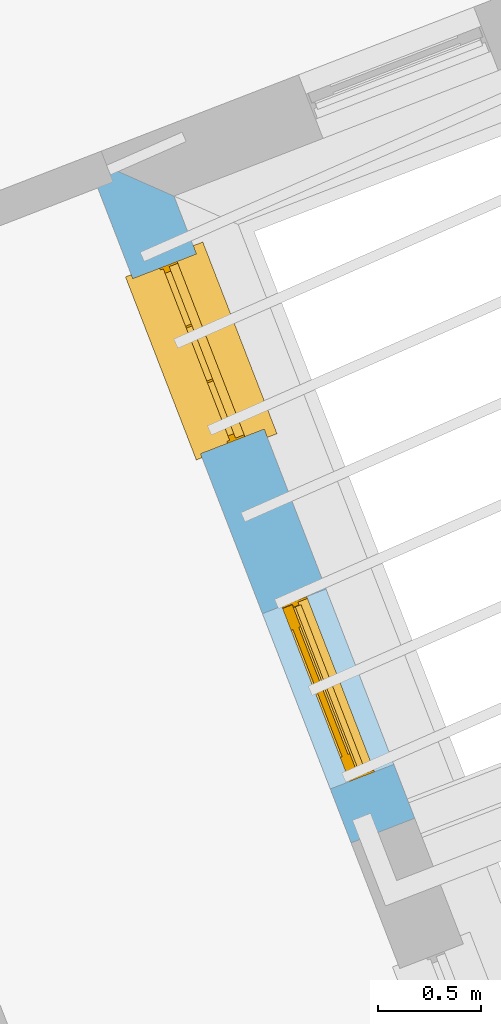
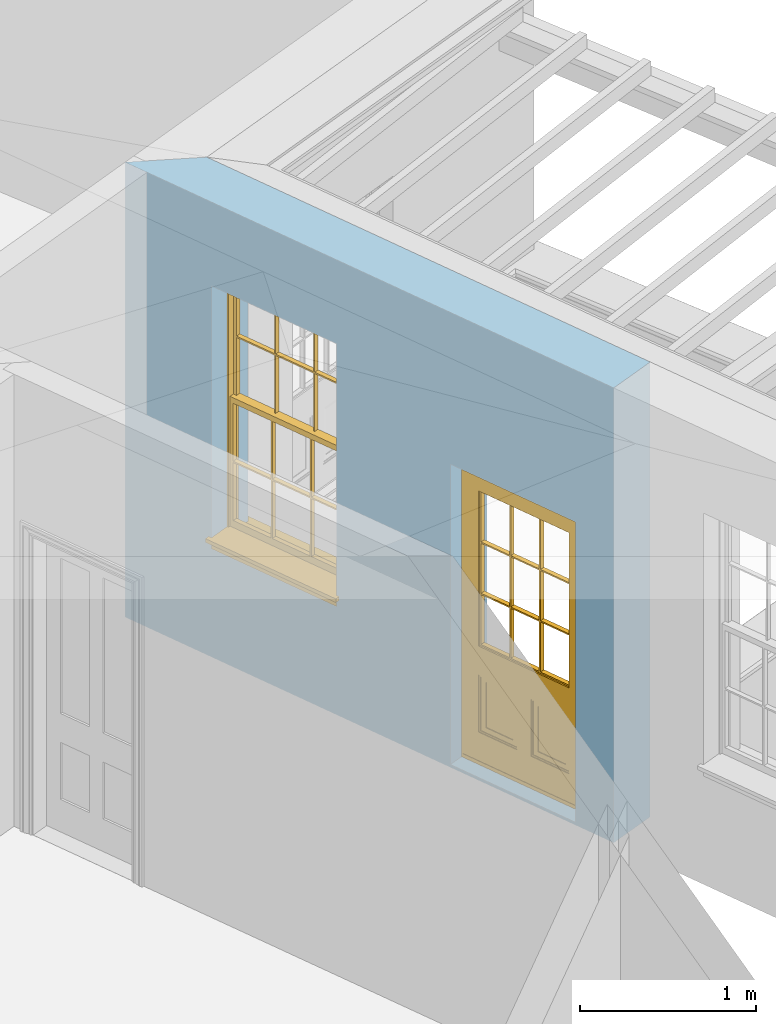
# One storey, part 6 of 11: 1 door, 1 window, 2 openings, plus 1 element that does not belong to this part.
"""IFC2X3 building model written with IfcOpenShell, lengths in metres."""

from ifc_helpers import new_model, si_unit, frame, origin, place, context, subcontext, project, spatial, polyline, outline, extrude, faceted_brep, material, layer, layer_set, layer_usage, element, fill, save


model = new_model("IFC2X3")

# Units and contexts
model_context = context("Model", 3, world=origin())
body_context = subcontext(model_context, "Body", "Model", "MODEL_VIEW")
ifc_project = project(units=[si_unit("PLANEANGLEUNIT", "RADIAN"), si_unit("MASSUNIT", "GRAM", prefix="KILO"), si_unit("FORCEUNIT", "NEWTON", prefix="KILO"), si_unit("LENGTHUNIT", "METRE")], contexts=[model_context])

# Site, building, storey
site_placement = place(None, origin())
site = spatial("IfcSite", under=ifc_project, at=site_placement, CompositionType="ELEMENT")
building_placement = place(None, origin())
building = spatial("IfcBuilding", under=site, at=building_placement, Name="Building plot-5", CompositionType="ELEMENT")
storey_placement = place(None, frame((0.0, 0.0, 7.6)))
storey = spatial("IfcBuildingStorey", under=building, at=storey_placement, Name="Floor 1", CompositionType="ELEMENT", Elevation=7.6)

# Wall, openings, door, window
ifc_material = material(Name="Masonry")
ifc_layer = layer(ifc_material, 0.33, ventilated=False)
ifc_layer_set = layer_set([ifc_layer], Name="My Wall")
ifc_layer_usage = layer_usage(ifc_layer_set, "AXIS2", "NEGATIVE", 0.08)
wall_placement = place(storey_placement, origin())
wall = element("IfcWallStandardCase", 1, at=wall_placement, inside=storey, material=ifc_layer_usage, Name="exterior", context=body_context, shape_type="SweptSolid", body=[
    extrude(outline(polyline([(63.1182699697019, 56.0491056208722), (63.4260314383826, 56.1681975114254), (62.2606962551514, 59.1796978397062), (61.8338428959176, 59.3683674178337), (63.1182699697019, 56.0491056208722)])), origin(), (0.0, 0.0, 1.0), 3.15),
])
opening_1_placement = place(storey_placement, frame((0.0, 0.0, 0.0199999999999996)))
opening_1 = element("IfcOpeningElement", 2, at=opening_1_placement, cuts=wall, Name="Opening", ObjectType="Opening", context=body_context, shape_type="SweptSolid", body=[
    extrude(outline(polyline([(63.3251446767321, 56.4289126431758), (62.9967397664188, 57.2775882083255), (62.6889782977382, 57.1584963177724), (63.0173832080514, 56.3098207526227), (63.3251446767321, 56.4289126431758)])), origin(), (0.0, 0.0, 1.0), 2.08),
])
opening_2_placement = place(storey_placement, frame((0.0, 0.0, 0.75)))
opening_2 = element("IfcOpeningElement", 3, at=opening_2_placement, cuts=wall, Name="Opening", ObjectType="Opening", context=body_context, shape_type="SweptSolid", body=[
    extrude(outline(polyline([(62.697366520513, 58.0512391212105), (62.3689616101998, 58.8999146863601), (62.0612001415191, 58.780822795807), (62.3896050518324, 57.9321472306573), (62.697366520513, 58.0512391212105)])), origin(), (0.0, 0.0, 1.0), 1.82),
])
door_placement = place(storey_placement, frame((63.0919920489437, 56.3386915139689, 0.0199999999999996), z_axis=(0.0, 0.0, 1.0), x_axis=(-0.328404910313289, 0.848675565149676, 0.0)))
door = element("IfcDoor", 4, at=door_placement, inside=storey, Name="circulation outside door", OverallHeight=2.08, OverallWidth=0.91, context=body_context, shape_type="Brep", held_by="IfcProductRepresentation", body=[
    faceted_brep([(0.545, -0.055, 0.265), (0.745, -0.055, 0.265), (0.745, -0.05, 0.265), (0.545, -0.05, 0.265), (0.745, -0.05, 0.58), (0.545, -0.05, 0.58), (0.545, -0.055, 0.58), (0.515, -0.06, 0.235), (0.775, -0.06, 0.235), (0.745, -0.055, 0.58), (0.515, -0.06, 0.61), (0.515, -0.065, 0.235), (0.775, -0.065, 0.235), (0.775, -0.06, 0.61), (0.515, -0.065, 0.61), (0.785, -0.065, 0.225), (0.505, -0.065, 0.225), (0.775, -0.065, 0.61), (0.505, -0.065, 0.62), (0.785, -0.065, 0.62), (0.505, -0.07, 0.225), (0.785, -0.07, 0.225), (0.505, -0.07, 0.62), (0.785, -0.07, 0.62), (0.883, -0.07, 0.075), (0.898, -0.07, 0.075), (0.405, -0.07, 0.62), (0.405, -0.07, 0.225), (0.027, -0.07, 0.075), (0.785, -0.07, 0.82), (0.125, -0.07, 0.82), (0.405, -0.065, 0.62), (0.405, -0.065, 0.225), (0.898, -0.07, 2.068), (0.027, -0.08, 0.075), (0.883, -0.08, 0.075), (0.125, -0.07, 0.225), (0.012, -0.07, 0.075), (0.785, -0.06, 0.82), (0.125, -0.06, 0.82), (0.125, -0.07, 0.62), (0.125, -0.065, 0.62), (0.395, -0.065, 0.61), (0.395, -0.065, 0.235), (0.125, -0.065, 0.225), (0.785, -0.07, 1.895), (0.027, -0.11, 0.045), (0.883, -0.11, 0.045), (0.558333, -0.06, 0.83), (0.351667, -0.06, 0.83), (0.125, -0.07, 1.895), (0.125, -0.06, 1.895), (0.785, -0.06, 1.895), (0.012, -0.07, 2.068), (0.135, -0.065, 0.61), (0.395, -0.06, 0.61), (0.395, -0.06, 0.235), (0.135, -0.065, 0.235), (0.027, -0.11, 0.027), (0.883, -0.11, 0.027), (0.568333, -0.06, 0.83), (0.558333, -0.03, 0.83), (0.351667, -0.03, 0.83), (0.341667, -0.06, 0.83), (0.135, -0.06, 1.185), (0.135, -0.06, 1.53), (0.775, -0.06, 1.53), (0.775, -0.06, 1.185), (0.135, -0.06, 0.61), (0.365, -0.055, 0.58), (0.365, -0.055, 0.265), (0.135, -0.06, 0.235), (0.568333, -0.06, 1.175), (0.558333, -0.06, 1.175), (0.775, -0.06, 0.83), (0.558333, -0.03, 1.175), (0.785, -0.03, 0.82), (0.125, -0.03, 0.82), (0.351667, -0.03, 1.175), (0.351667, -0.06, 1.175), (0.341667, -0.06, 1.175), (0.135, -0.06, 0.83), (0.135, -0.06, 1.175), (0.135, -0.03, 1.185), (0.135, -0.03, 1.53), (0.135, -0.06, 1.54), (0.351667, -0.06, 1.885), (0.558333, -0.06, 1.885), (0.775, -0.03, 1.53), (0.775, -0.03, 1.185), (0.775, -0.06, 1.175), (0.775, -0.06, 1.54), (0.165, -0.055, 0.58), (0.365, -0.05, 0.58), (0.365, -0.05, 0.265), (0.165, -0.055, 0.265), (0.568333, -0.03, 0.83), (0.568333, -0.03, 1.175), (0.568333, -0.06, 1.185), (0.558333, -0.06, 1.185), (0.775, -0.03, 0.83), (0.785, -0.02, 0.82), (0.125, -0.02, 0.82), (0.341667, -0.03, 0.83), (0.341667, -0.03, 1.175), (0.351667, -0.06, 1.185), (0.341667, -0.06, 1.185), (0.135, -0.03, 0.83), (0.341667, -0.03, 1.185), (0.125, -0.03, 1.895), (0.341667, -0.03, 1.53), (0.341667, -0.06, 1.53), (0.135, -0.06, 1.885), (0.341667, -0.06, 1.54), (0.341667, -0.06, 1.885), (0.558333, -0.03, 1.885), (0.351667, -0.03, 1.885), (0.568333, -0.06, 1.885), (0.785, -0.03, 1.895), (0.568333, -0.03, 1.185), (0.568333, -0.06, 1.53), (0.568333, -0.03, 1.53), (0.568333, -0.06, 1.54), (0.775, -0.06, 1.885), (0.165, -0.05, 0.58), (0.165, -0.05, 0.265), (0.775, -0.03, 1.175), (0.558333, -0.06, 1.53), (0.351667, -0.03, 1.185), (0.558333, -0.03, 1.185), (0.505, -0.02, 0.62), (0.405, -0.02, 0.62), (0.125, -0.02, 1.895), (0.785, -0.02, 1.895), (0.351667, -0.06, 1.53), (0.135, -0.03, 1.175), (0.135, -0.03, 1.54), (0.341667, -0.03, 1.54), (0.135, -0.03, 1.885), (0.351667, -0.06, 1.54), (0.558333, -0.03, 1.54), (0.558333, -0.06, 1.54), (0.351667, -0.03, 1.54), (0.775, -0.03, 1.54), (0.568333, -0.03, 1.54), (0.775, -0.03, 1.885), (0.558333, -0.03, 1.53), (0.405, -0.02, 0.225), (0.505, -0.02, 0.225), (0.125, -0.02, 0.62), (0.785, -0.02, 0.62), (0.012, -0.02, 2.068), (0.898, -0.02, 2.068), (0.351667, -0.03, 1.53), (0.341667, -0.03, 1.885), (0.568333, -0.03, 1.885), (0.405, -0.025, 0.225), (0.405, -0.025, 0.62), (0.505, -0.025, 0.62), (0.505, -0.025, 0.225), (0.898, -0.02, 0.027), (0.012, -0.02, 0.027), (0.125, -0.025, 0.62), (0.785, -0.025, 0.62), (0.395, -0.025, 0.235), (0.395, -0.025, 0.61), (0.125, -0.02, 0.225), (0.125, -0.025, 0.225), (0.515, -0.025, 0.61), (0.515, -0.025, 0.235), (0.785, -0.02, 0.225), (0.785, -0.025, 0.225), (0.135, -0.025, 0.61), (0.775, -0.025, 0.61), (0.135, -0.025, 0.235), (0.395, -0.03, 0.235), (0.395, -0.03, 0.61), (0.515, -0.03, 0.61), (0.515, -0.03, 0.235), (0.775, -0.025, 0.235), (0.135, -0.03, 0.61), (0.775, -0.03, 0.61), (0.135, -0.03, 0.235), (0.365, -0.035, 0.265), (0.365, -0.035, 0.58), (0.545, -0.035, 0.58), (0.545, -0.035, 0.265), (0.775, -0.03, 0.235), (0.165, -0.035, 0.58), (0.745, -0.035, 0.58), (0.165, -0.035, 0.265), (0.365, -0.04, 0.58), (0.365, -0.04, 0.265), (0.545, -0.04, 0.58), (0.545, -0.04, 0.265), (0.745, -0.035, 0.265), (0.165, -0.04, 0.58), (0.745, -0.04, 0.58), (0.165, -0.04, 0.265), (0.745, -0.04, 0.265), (0.885, -0.072, 0.025), (0.025, -0.072, 0.025), (0.025, -0.1, 0.025), (0.885, -0.1, 0.025), (0.9, -0.02, 0.025), (0.01, -0.02, 0.025), (0.9, -0.072, 0.025), (0.91, -0.02, 0.0), (0.0, -0.02, 0.0), (0.01, -0.072, 0.025), (0.9, -0.072, 2.07), (0.9, -0.02, 2.07), (0.885, -0.072, 2.055), (0.91, -0.02, 2.08), (0.01, -0.02, 2.07), (0.0, -0.02, 2.08), (0.01, -0.072, 2.07), (0.025, -0.072, 2.055), (0.0, -0.15, 2.08), (0.91, -0.15, 2.08), (0.01, -0.15, 2.07), (0.9, -0.15, 2.07), (0.01, -0.1, 2.07), (0.9, -0.1, 2.07), (0.0, -0.15, 0.0), (0.91, -0.15, 0.0), (0.01, -0.15, 0.025), (0.9, -0.15, 0.025), (0.01, -0.1, 0.025), (0.025, -0.1, 2.055), (0.9, -0.1, 0.025), (0.885, -0.1, 2.055), (0.898, -0.07, 0.027), (0.012, -0.07, 0.027), (0.883, -0.07, 0.027), (0.027, -0.07, 0.027)], [[[0, 1, 2, 3]], [[2, 4, 5, 3]], [[0, 3, 5, 6]], [[1, 0, 7, 8]], [[9, 4, 2, 1]], [[9, 6, 5, 4]], [[0, 6, 10, 7]], [[8, 7, 11, 12]], [[8, 13, 9, 1]], [[13, 10, 6, 9]], [[7, 10, 14, 11]], [[15, 12, 11, 16]], [[12, 17, 13, 8]], [[17, 14, 10, 13]], [[18, 16, 11, 14]], [[15, 19, 17, 12]], [[15, 16, 20, 21]], [[14, 17, 19, 18]], [[16, 18, 22, 20]], [[21, 23, 19, 15]], [[24, 25, 21, 20]], [[23, 22, 18, 19]], [[20, 22, 26, 27]], [[23, 21, 25]], [[28, 24, 20, 27]], [[22, 23, 29]], [[29, 30, 26, 22]], [[27, 26, 31, 32]], [[23, 25, 33, 29]], [[34, 35, 24, 28]], [[28, 27, 36, 37]], [[38, 39, 30, 29]], [[26, 30, 40]], [[26, 40, 41, 31]], [[42, 43, 32, 31]], [[32, 44, 36, 27]], [[33, 45, 29]], [[46, 47, 35, 34]], [[36, 40, 37]], [[39, 38, 48, 49]], [[50, 30, 39, 51]], [[29, 45, 52, 38]], [[53, 37, 40, 30]], [[44, 41, 40, 36]], [[31, 41, 54, 42]], [[43, 42, 55, 56]], [[57, 44, 32, 43]], [[50, 45, 33, 53]], [[47, 46, 58, 59]], [[60, 48, 38]], [[49, 48, 61, 62]], [[49, 63, 39]], [[50, 53, 30]], [[51, 39, 64, 65]], [[45, 50, 51, 52]], [[66, 67, 38, 52]], [[57, 54, 41, 44]], [[42, 54, 68, 55]], [[56, 55, 69, 70]], [[56, 71, 57, 43]], [[60, 72, 73, 48]], [[60, 38, 74]], [[48, 73, 75, 61]], [[76, 77, 62, 61]], [[62, 78, 79, 49]], [[49, 79, 80, 63]], [[63, 81, 39]], [[82, 64, 39]], [[65, 64, 83, 84]], [[85, 51, 65]], [[52, 51, 86, 87]], [[88, 89, 67, 66]], [[90, 38, 67]], [[91, 66, 52]], [[71, 68, 54, 57]], [[55, 68, 92, 69]], [[69, 93, 94, 70]], [[70, 95, 71, 56]], [[96, 97, 72, 60]], [[73, 72, 98, 99]], [[74, 38, 90]], [[100, 96, 60, 74]], [[75, 73, 79, 78]], [[61, 75, 97, 96]], [[101, 102, 77, 76]], [[77, 103, 62]], [[96, 76, 61]], [[103, 104, 78, 62]], [[80, 79, 105, 106]], [[63, 80, 104, 103]], [[81, 63, 103, 107]], [[81, 82, 39]], [[106, 64, 82, 80]], [[106, 108, 83, 64]], [[84, 83, 77, 109]], [[110, 111, 65, 84]], [[112, 51, 85]], [[113, 85, 65, 111]], [[114, 86, 51]], [[115, 87, 86, 116]], [[117, 52, 87]], [[118, 76, 89, 88]], [[119, 98, 67, 89]], [[120, 121, 88, 66]], [[67, 98, 72, 90]], [[91, 122, 120, 66]], [[91, 52, 123]], [[95, 92, 68, 71]], [[69, 92, 124, 93]], [[94, 93, 124, 125]], [[94, 125, 95, 70]], [[72, 97, 126, 90]], [[127, 99, 98, 120]], [[99, 105, 79, 73]], [[74, 90, 126, 100]], [[96, 100, 76]], [[128, 129, 75, 78]], [[97, 75, 129, 119]], [[130, 131, 102, 101]], [[109, 77, 102, 132]], [[133, 101, 76, 118]], [[77, 107, 103]], [[78, 104, 108, 128]], [[111, 106, 105, 134]], [[104, 80, 82, 135]], [[107, 135, 82, 81]], [[110, 108, 106, 111]], [[104, 135, 83, 108]], [[83, 135, 77]], [[136, 84, 109]], [[110, 84, 136, 137]], [[114, 51, 112]], [[85, 136, 138, 112]], [[113, 137, 136, 85]], [[111, 134, 139, 113]], [[86, 114, 113, 139]], [[140, 141, 87, 115]], [[139, 142, 116, 86]], [[109, 118, 115, 116]], [[117, 123, 52]], [[117, 87, 141, 122]], [[126, 89, 76]], [[143, 118, 88]], [[120, 98, 119, 121]], [[119, 89, 126, 97]], [[144, 143, 88, 121]], [[144, 122, 91, 143]], [[127, 120, 122, 141]], [[143, 91, 123, 145]], [[124, 92, 95, 125]], [[146, 129, 99, 127]], [[99, 129, 128, 105]], [[100, 126, 76]], [[121, 119, 129, 146]], [[147, 131, 130, 148]], [[131, 149, 102]], [[130, 101, 150]], [[102, 151, 132]], [[118, 109, 132, 133]], [[101, 133, 152]], [[107, 77, 135]], [[153, 128, 108, 110]], [[134, 105, 128, 153]], [[109, 138, 136]], [[153, 110, 137, 142]], [[154, 114, 112, 138]], [[137, 113, 114, 154]], [[141, 139, 134, 127]], [[141, 140, 142, 139]], [[144, 140, 115, 155]], [[142, 137, 154, 116]], [[155, 115, 118]], [[116, 154, 109]], [[117, 155, 145, 123]], [[122, 144, 155, 117]], [[143, 145, 118]], [[121, 146, 140, 144]], [[146, 127, 134, 153]], [[156, 157, 131, 147]], [[148, 130, 158, 159]], [[148, 160, 161, 147]], [[157, 162, 149, 131]], [[161, 151, 102, 149]], [[101, 152, 160, 150]], [[163, 158, 130, 150]], [[151, 152, 133, 132]], [[154, 138, 109]], [[142, 140, 146, 153]], [[145, 155, 118]], [[157, 156, 164, 165]], [[147, 166, 167, 156]], [[168, 169, 159, 158]], [[170, 148, 159, 171]], [[148, 170, 160]], [[166, 147, 161]], [[172, 162, 157, 165]], [[166, 149, 162, 167]], [[166, 161, 149]], [[150, 160, 170]], [[163, 173, 168, 158]], [[171, 163, 150, 170]], [[174, 164, 156, 167]], [[175, 176, 165, 164]], [[169, 168, 177, 178]], [[171, 159, 169, 179]], [[167, 162, 172, 174]], [[176, 180, 172, 165]], [[179, 173, 163, 171]], [[181, 177, 168, 173]], [[164, 174, 182, 175]], [[183, 184, 176, 175]], [[178, 177, 185, 186]], [[179, 169, 178, 187]], [[174, 172, 180, 182]], [[184, 188, 180, 176]], [[187, 181, 173, 179]], [[189, 185, 177, 181]], [[175, 182, 190, 183]], [[191, 184, 183, 192]], [[185, 193, 194, 186]], [[187, 178, 186, 195]], [[182, 180, 188, 190]], [[191, 196, 188, 184]], [[195, 189, 181, 187]], [[197, 193, 185, 189]], [[183, 190, 198, 192]], [[198, 196, 191, 192]], [[194, 193, 197, 199]], [[195, 186, 194, 199]], [[188, 196, 198, 190]], [[197, 189, 195, 199]], [[200, 201, 202, 203]], [[201, 200, 204, 205]], [[206, 204, 200]], [[204, 207, 208, 205]], [[209, 201, 205]], [[210, 211, 204, 206]], [[206, 200, 212, 210]], [[211, 213, 207, 204]], [[214, 205, 208, 215]], [[216, 217, 201, 209]], [[205, 214, 216, 209]], [[216, 214, 211, 210]], [[210, 212, 217, 216]], [[214, 215, 213, 211]], [[218, 219, 213, 215]], [[219, 218, 220, 221]], [[221, 220, 222, 223]], [[215, 208, 224, 218]], [[225, 224, 208, 207]], [[224, 226, 220, 218]], [[224, 225, 227, 226]], [[219, 225, 207, 213]], [[228, 222, 220, 226]], [[219, 221, 227, 225]], [[226, 227, 203, 202]], [[202, 229, 222, 228]], [[228, 226, 202]], [[227, 221, 223, 230]], [[230, 203, 227]], [[217, 229, 202, 201]], [[231, 223, 222, 229]], [[230, 223, 231, 203]], [[231, 229, 217, 212]], [[212, 200, 203, 231]], [[33, 152, 151, 53]], [[25, 160, 152, 33]], [[161, 37, 53, 151]], [[232, 160, 25]], [[161, 233, 37]], [[160, 232, 234]], [[24, 234, 232, 25]], [[233, 161, 235]], [[37, 233, 235, 28]], [[161, 160, 234, 235]], [[35, 47, 234, 24]], [[28, 235, 46, 34]], [[58, 235, 234, 59]], [[59, 234, 47]], [[58, 46, 235]]]),
])
fill(opening_1, door)
window_placement = place(storey_placement, frame((62.4642138927247, 57.9610179920035, 0.75), z_axis=(0.0, 0.0, 1.0), x_axis=(-0.328404910313289, 0.848675565149676, 0.0)))
window = element("IfcWindow", 5, at=window_placement, inside=storey, Name="circulation outside window", OverallHeight=1.82, OverallWidth=0.91, context=body_context, shape_type="Brep", held_by="IfcProductRepresentation", body=[
    faceted_brep([(0.033125, -0.105, 0.975209), (0.01, -0.105, 0.975209), (0.033125, -0.105, 1.376042), (0.876875, -0.105, 0.975209), (0.876875, -0.105, 1.376042), (0.9, -0.105, 0.975209), (0.876875, -0.105, 1.386042), (0.876875, -0.105, 1.786875), (0.9, -0.105, 1.81), (0.033125, -0.105, 1.786875), (0.033125, -0.105, 1.386042), (0.01, -0.105, 1.81), (0.876875, -0.135, 1.376042), (0.876875, -0.135, 0.975209), (0.9, -0.135, 0.937083), (0.033125, -0.135, 1.786875), (0.01, -0.135, 1.81), (0.033125, -0.135, 1.386042), (0.01, -0.135, 0.937083), (0.033125, -0.135, 0.975209), (0.033125, -0.135, 1.376042), (0.876875, -0.135, 1.786875), (0.876875, -0.135, 1.386042), (0.9, -0.135, 1.81), (0.033125, -0.105, 0.937083), (0.01, -0.105, 0.937083), (0.033125, -0.105, 0.53625), (0.876875, -0.105, 0.937083), (0.876875, -0.105, 0.53625), (0.9, -0.105, 0.937083), (0.876875, -0.105, 0.52625), (0.876875, -0.105, 0.125417), (0.9, -0.105, 0.077167), (0.033125, -0.105, 0.125417), (0.033125, -0.105, 0.52625), (0.01, -0.105, 0.077167), (-0.0425, -0.25, 0.01), (-0.0425, -0.3, 0.001667), (0.0, -0.25, 0.01), (0.9525, -0.25, 0.01), (0.91, -0.25, 0.01), (0.9525, -0.3, 0.001667), (-0.02, 0.08, 0.077167), (0.0, 0.08, 0.077167), (-0.02, 0.11, 0.077167), (0.0, -0.06, 0.077167), (0.01, -0.06, 0.077167), (0.91, -0.06, 0.077167), (0.91, 0.08, 0.077167), (0.9, -0.06, 0.077167), (0.93, 0.08, 0.077167), (0.93, 0.11, 0.077167), (0.01, -0.075, 0.975209), (0.9, -0.075, 0.975209), (0.876875, -0.075, 0.125417), (0.876875, -0.075, 0.52625), (0.9, -0.075, 0.077167), (0.876875, -0.075, 0.53625), (0.876875, -0.075, 0.937083), (0.033125, -0.075, 0.125417), (0.01, -0.075, 0.077167), (0.033125, -0.075, 0.52625), (0.033125, -0.075, 0.937083), (0.033125, -0.075, 0.53625), (-0.02, 0.08, 0.052167), (-0.02, 0.11, 0.052167), (0.93, 0.11, 0.052167), (0.93, 0.08, 0.052167), (0.91, 0.08, 0.052167), (0.0, 0.08, 0.052167), (0.91, -0.15, 0.026667), (0.0, -0.15, 0.026667), (-0.0425, -0.3, -0.123333), (0.9525, -0.3, -0.123333), (-0.0425, -0.25, -0.123333), (0.9525, -0.25, -0.123333), (0.01, -0.06, 1.81), (0.9, -0.06, 1.81), (0.0, -0.06, 1.82), (0.91, -0.06, 1.82), (0.01, -0.15, 0.077167), (0.9, -0.15, 0.077167), (0.592292, -0.105, 0.125417), (0.592292, -0.075, 0.125417), (0.317708, -0.075, 0.125417), (0.317708, -0.105, 0.125417), (0.592292, -0.105, 0.53625), (0.317708, -0.105, 0.53625), (0.317708, -0.105, 0.52625), (0.592292, -0.105, 0.52625), (0.592292, -0.075, 0.53625), (0.317708, -0.075, 0.53625), (0.592292, -0.135, 1.386042), (0.592292, -0.105, 1.386042), (0.317708, -0.105, 1.386042), (0.317708, -0.135, 1.386042), (0.317708, -0.135, 1.376042), (0.592292, -0.135, 1.376042), (0.317708, -0.105, 1.376042), (0.592292, -0.105, 1.376042), (0.602292, -0.135, 1.376042), (0.592292, -0.135, 0.975209), (0.602292, -0.135, 0.975209), (0.602292, -0.105, 0.975209), (0.592292, -0.105, 0.975209), (0.602292, -0.105, 1.376042), (0.602292, -0.075, 0.53625), (0.602292, -0.105, 0.53625), (0.317708, -0.075, 0.52625), (0.307708, -0.075, 0.125417), (0.307708, -0.075, 0.52625), (0.602292, -0.075, 0.52625), (0.602292, -0.075, 0.125417), (0.592292, -0.075, 0.52625), (0.307708, -0.075, 0.53625), (0.317708, -0.075, 0.937083), (0.307708, -0.075, 0.937083), (0.602292, -0.075, 0.937083), (0.592292, -0.075, 0.937083), (0.307708, -0.105, 0.52625), (0.307708, -0.105, 0.125417), (0.307708, -0.105, 0.53625), (0.307708, -0.105, 0.937083), (0.592292, -0.105, 0.937083), (0.317708, -0.105, 0.937083), (0.602292, -0.105, 0.937083), (0.602292, -0.105, 0.52625), (0.602292, -0.105, 0.125417), (0.307708, -0.135, 1.386042), (0.307708, -0.135, 1.376042), (0.307708, -0.135, 0.975209), (0.317708, -0.135, 0.975209), (0.317708, -0.135, 1.786875), (0.307708, -0.135, 1.786875), (0.602292, -0.135, 1.786875), (0.592292, -0.135, 1.786875), (0.602292, -0.135, 1.386042), (0.602292, -0.105, 1.386042), (0.307708, -0.105, 1.386042), (0.307708, -0.105, 1.786875), (0.317708, -0.105, 1.786875), (0.592292, -0.105, 1.786875), (0.602292, -0.105, 1.786875), (0.307708, -0.105, 1.376042), (0.317708, -0.105, 0.975209), (0.307708, -0.105, 0.975209), (0.91, -0.15, 1.82), (0.9, -0.15, 1.81), (0.01, -0.15, 1.81), (0.0, -0.15, 1.82), (0.91, -0.25, 0.0), (0.0, -0.25, 0.0), (0.91, 0.08, 0.0), (0.0, 0.08, 0.0)], [[[0, 1, 2]], [[3, 4, 5]], [[6, 7, 8]], [[9, 10, 11]], [[12, 13, 14]], [[15, 16, 17]], [[18, 19, 20]], [[21, 22, 23]], [[24, 25, 26]], [[27, 28, 29]], [[30, 31, 32]], [[33, 34, 35]], [[14, 27, 29]], [[25, 24, 18]], [[36, 37, 38]], [[39, 40, 41]], [[42, 43, 44]], [[45, 46, 43]], [[47, 48, 49]], [[50, 51, 48]], [[1, 0, 52]], [[5, 53, 3]], [[54, 55, 56]], [[57, 58, 53]], [[59, 60, 61]], [[62, 63, 52]], [[48, 43, 46, 49]], [[51, 44, 43, 48]], [[64, 42, 44, 65]], [[65, 44, 51, 66]], [[66, 51, 50, 67]], [[65, 66, 68, 69]], [[60, 56, 49, 46]], [[70, 71, 38, 40]], [[37, 41, 40, 38]], [[37, 72, 73, 41]], [[74, 75, 73, 72]], [[8, 11, 76, 77]], [[76, 78, 79, 77]], [[32, 35, 80, 81]], [[81, 80, 71, 70]], [[82, 83, 84, 85]], [[86, 87, 88, 89]], [[86, 90, 91, 87]], [[92, 93, 94, 95]], [[92, 95, 96, 97]], [[96, 98, 99, 97]], [[100, 97, 101, 102]], [[103, 104, 99, 105]], [[97, 99, 104, 101]], [[102, 103, 105, 100]], [[28, 57, 106, 107]], [[108, 84, 109, 110]], [[111, 112, 83, 113]], [[114, 110, 61, 63]], [[90, 113, 108, 91]], [[115, 91, 114, 116]], [[117, 106, 90, 118]], [[111, 106, 57, 55]], [[119, 110, 109, 120]], [[34, 61, 110, 119]], [[89, 113, 83, 82]], [[88, 108, 113, 89]], [[85, 84, 108, 88]], [[121, 114, 63, 26]], [[122, 116, 114, 121]], [[123, 118, 90, 86]], [[87, 91, 115, 124]], [[107, 106, 117, 125]], [[126, 111, 55, 30]], [[127, 112, 111, 126]], [[126, 30, 28, 107]], [[88, 119, 120, 85]], [[126, 89, 82, 127]], [[125, 123, 86, 107]], [[121, 26, 34, 119]], [[124, 122, 121, 87]], [[128, 17, 20, 129]], [[96, 129, 130, 131]], [[132, 133, 128, 95]], [[134, 135, 92, 136]], [[100, 12, 22, 136]], [[137, 6, 4, 105]], [[94, 138, 139, 140]], [[137, 93, 141, 142]], [[99, 98, 94, 93]], [[143, 2, 10, 138]], [[144, 145, 143, 98]], [[129, 143, 145, 130]], [[20, 2, 143, 129]], [[131, 144, 98, 96]], [[128, 138, 10, 17]], [[133, 139, 138, 128]], [[135, 141, 93, 92]], [[95, 94, 140, 132]], [[22, 6, 137, 136]], [[136, 137, 142, 134]], [[100, 105, 4, 12]], [[107, 86, 89, 126]], [[106, 111, 113, 90]], [[91, 108, 110, 114]], [[87, 121, 119, 88]], [[97, 100, 136, 92]], [[129, 96, 95, 128]], [[98, 143, 138, 94]], [[105, 99, 93, 137]], [[131, 101, 104, 144]], [[124, 115, 118, 123]], [[132, 140, 141, 135]], [[120, 109, 59, 33]], [[15, 9, 139, 133]], [[134, 142, 7, 21]], [[31, 54, 112, 127]], [[36, 74, 72, 37]], [[39, 41, 73, 75]], [[18, 14, 101, 131]], [[23, 16, 132, 135]], [[83, 56, 60, 84]], [[52, 53, 118, 115]], [[53, 52, 144, 104]], [[11, 8, 141, 140]], [[14, 18, 124, 123]], [[2, 1, 11, 10]], [[8, 5, 4, 6]], [[57, 53, 56, 55]], [[60, 52, 63, 61]], [[26, 25, 35, 34]], [[32, 29, 28, 30]], [[14, 23, 22, 12]], [[18, 20, 17, 16]], [[19, 0, 2, 20]], [[17, 10, 9, 15]], [[12, 4, 3, 13]], [[21, 7, 6, 22]], [[27, 58, 57, 28]], [[30, 55, 54, 31]], [[33, 59, 61, 34]], [[26, 63, 62, 24]], [[5, 8, 77, 53]], [[76, 11, 1, 52]], [[46, 45, 78, 76]], [[49, 77, 79, 47]], [[70, 146, 147, 81]], [[71, 80, 148, 149]], [[19, 130, 145, 0]], [[102, 13, 3, 103]], [[116, 122, 24, 62]], [[29, 32, 81, 14]], [[80, 35, 25, 18]], [[60, 46, 76, 52]], [[77, 49, 56, 53]], [[23, 14, 81, 147]], [[16, 148, 80, 18]], [[35, 85, 120]], [[120, 33, 35]], [[127, 82, 32]], [[32, 31, 127]], [[32, 82, 85, 35]], [[102, 101, 14]], [[14, 13, 102]], [[18, 131, 130]], [[130, 19, 18]], [[134, 21, 23]], [[23, 135, 134]], [[16, 15, 133]], [[133, 132, 16]], [[11, 140, 139]], [[139, 9, 11]], [[142, 141, 8]], [[8, 7, 142]], [[23, 147, 148, 16]], [[146, 149, 148, 147]], [[52, 115, 116]], [[116, 62, 52]], [[118, 53, 117]], [[58, 117, 53]], [[27, 125, 117, 58]], [[56, 83, 112]], [[112, 54, 56]], [[109, 84, 60]], [[60, 59, 109]], [[125, 27, 14]], [[14, 123, 125]], [[122, 124, 18]], [[18, 24, 122]], [[145, 144, 52]], [[52, 0, 145]], [[103, 3, 53]], [[53, 104, 103]], [[79, 78, 149, 146]], [[78, 45, 71, 149]], [[146, 70, 47, 79]], [[150, 75, 74, 151]], [[68, 66, 67]], [[48, 68, 67, 50]], [[69, 64, 65]], [[42, 64, 69, 43]], [[69, 68, 152, 153]], [[70, 68, 48, 47]], [[150, 152, 68, 70]], [[43, 69, 71, 45]], [[69, 153, 151, 71]], [[152, 150, 151, 153]], [[38, 151, 74, 36]], [[71, 151, 38]], [[39, 75, 150, 40]], [[40, 150, 70]]]),
])
fill(opening_2, window)

save(model, "model.ifc")
